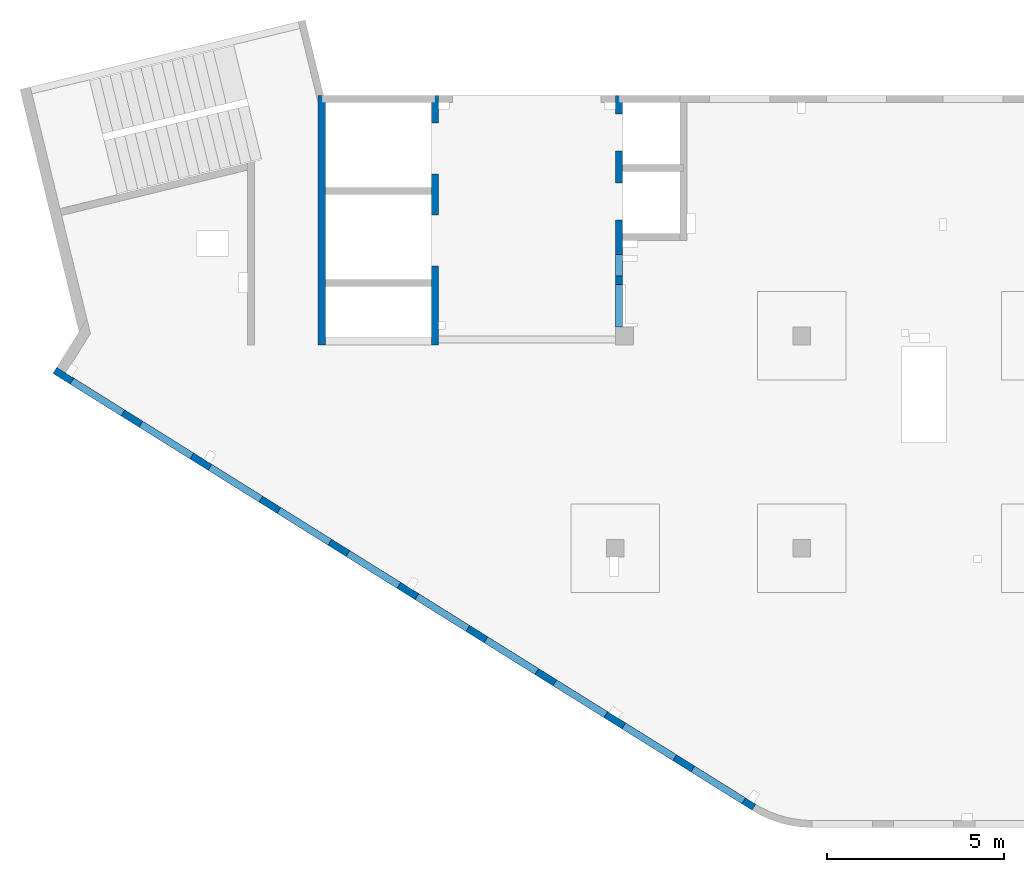
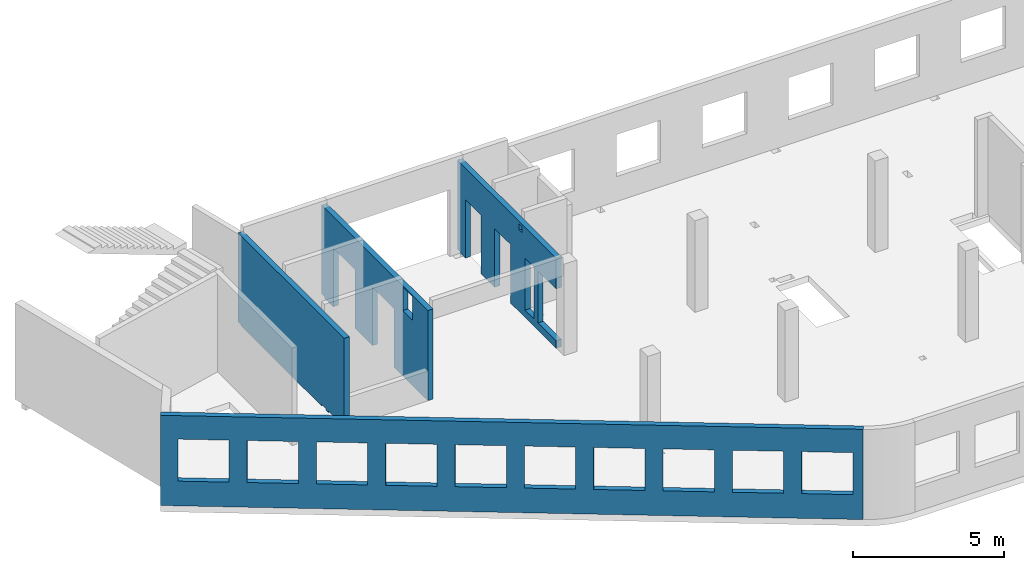
# One storey, part 4 of 6: 4 walls, 22 openings.
"""IFC4 building model written with IfcOpenShell, lengths in millimetres."""

from ifc_helpers import new_model, entity, si_unit, converted_unit, derived_unit, direction, frame, origin, place, context, subcontext, project, spatial, indexed_curve, outline, extrude, polygons, material, type_object, element, save


model = new_model("IFC4")

# Units and contexts
model_context = context("Model", 3, precision=0.01, world=origin(), true_north=direction((6.12303176911189e-17, 1.0)))
plan_context = context("Plan", 3, precision=0.01, world=origin(), true_north=direction((6.12303176911189e-17, 1.0)))
body_context = subcontext(model_context, "Body", "Model", "MODEL_VIEW")
ifc_project = project(units=[si_unit("LENGTHUNIT", "METRE", prefix="MILLI"), si_unit("AREAUNIT", "SQUARE_METRE"), si_unit("VOLUMEUNIT", "CUBIC_METRE"), converted_unit("PLANEANGLEUNIT", "DEGREE", entity("IfcRatioMeasure", 0.0174532925199433), si_unit("PLANEANGLEUNIT", "RADIAN"), dimensions=[0, 0, 0, 0, 0, 0, 0]), si_unit("MASSUNIT", "GRAM", prefix="KILO"), derived_unit("MASSDENSITYUNIT", [(si_unit("MASSUNIT", "GRAM", prefix="KILO"), 1), (si_unit("LENGTHUNIT", "METRE"), -3)]), derived_unit("MOMENTOFINERTIAUNIT", [(si_unit("LENGTHUNIT", "METRE"), 4)]), si_unit("TIMEUNIT", "SECOND"), si_unit("FREQUENCYUNIT", "HERTZ"), si_unit("THERMODYNAMICTEMPERATUREUNIT", "DEGREE_CELSIUS"), derived_unit("THERMALTRANSMITTANCEUNIT", [(si_unit("MASSUNIT", "GRAM", prefix="KILO"), 1), (si_unit("THERMODYNAMICTEMPERATUREUNIT", "KELVIN"), -1), (si_unit("TIMEUNIT", "SECOND"), -3)]), derived_unit("VOLUMETRICFLOWRATEUNIT", [(si_unit("LENGTHUNIT", "METRE"), 3), (si_unit("TIMEUNIT", "SECOND"), -1)]), derived_unit("MASSFLOWRATEUNIT", [(si_unit("MASSUNIT", "GRAM", prefix="KILO"), 1), (si_unit("TIMEUNIT", "SECOND"), -1)]), derived_unit("ROTATIONALFREQUENCYUNIT", [(si_unit("TIMEUNIT", "SECOND"), -1)]), si_unit("ELECTRICCURRENTUNIT", "AMPERE"), si_unit("ELECTRICVOLTAGEUNIT", "VOLT"), si_unit("POWERUNIT", "WATT"), si_unit("FORCEUNIT", "NEWTON", prefix="KILO"), si_unit("ILLUMINANCEUNIT", "LUX"), si_unit("LUMINOUSFLUXUNIT", "LUMEN"), si_unit("LUMINOUSINTENSITYUNIT", "CANDELA"), derived_unit("USERDEFINED", [(si_unit("MASSUNIT", "GRAM", prefix="KILO"), -1), (si_unit("LENGTHUNIT", "METRE"), -2), (si_unit("TIMEUNIT", "SECOND"), 3), (si_unit("LUMINOUSFLUXUNIT", "LUMEN"), 1)]), derived_unit("LINEARVELOCITYUNIT", [(si_unit("LENGTHUNIT", "METRE"), 1), (si_unit("TIMEUNIT", "SECOND"), -1)]), si_unit("PRESSUREUNIT", "PASCAL"), derived_unit("USERDEFINED", [(si_unit("LENGTHUNIT", "METRE"), -2), (si_unit("MASSUNIT", "GRAM", prefix="KILO"), 1), (si_unit("TIMEUNIT", "SECOND"), -2)]), derived_unit("LINEARFORCEUNIT", [(si_unit("MASSUNIT", "GRAM", prefix="KILO"), 1), (si_unit("LENGTHUNIT", "METRE"), 1), (si_unit("TIMEUNIT", "SECOND"), -2), (si_unit("LENGTHUNIT", "METRE"), -1)]), derived_unit("PLANARFORCEUNIT", [(si_unit("MASSUNIT", "GRAM", prefix="KILO"), 1), (si_unit("LENGTHUNIT", "METRE"), 1), (si_unit("TIMEUNIT", "SECOND"), -2), (si_unit("LENGTHUNIT", "METRE"), -2)])], contexts=[model_context, plan_context])

# Site, building, storey
site_placement = place(None, origin())
site = spatial("IfcSite", under=ifc_project, at=site_placement, CompositionType="ELEMENT")
building_placement = place(site_placement, origin())
building = spatial("IfcBuilding", under=site, at=building_placement, CompositionType="ELEMENT")
storey_placement = place(building_placement, frame((0.0, 0.0, 12000.0)))
storey = spatial("IfcBuildingStorey", under=building, at=storey_placement, Name="04", CompositionType="ELEMENT", Elevation=12000.0)

# Wall, openings
ifc_material = material()
wall_type = type_object("IfcWallType", Name=":ADSK_ 25_200", PredefinedType="STANDARD")
wall_1_placement = place(storey_placement, frame((19822.35, 371.16, -150.0), z_axis=(0.0, 0.0, 1.0), x_axis=(-0.848052743777574, 0.529911826412025, 0.0)))
wall_1 = element("IfcWall", 1, at=wall_1_placement, inside=storey, type_object=wall_type, material=ifc_material, Name=":ADSK_ 25_200", ObjectType=":ADSK_ 25_200", PredefinedType="NOTDEFINED", context=body_context, shape_type="Tessellation", body=[
    polygons([(-1.48894230278529e-12, -99.9999999999978, 0.0), (23011.6394501553, -99.9999999999989, 0.0), (23311.6394501553, -99.9999999999989, 0.0), (23311.6394501553, -99.9999999999989, 3650.0), (23011.6394501553, -99.9999999999989, 3650.0), (-1.48894230278529e-12, -99.9999999999978, 3650.0), (341.63903172165, -99.9999999999988, 2699.99999999999), (2041.63903172165, -99.9999999999981, 2699.99999999999), (2041.63903172165, -99.9999999999981, 1000.00000000001), (341.63903172165, -99.9999999999988, 1000.00000000001), (2641.63903172165, -99.9999999999995, 2699.99999999999), (4341.63903172165, -99.9999999999992, 2699.99999999999), (4341.63903172165, -99.9999999999992, 1000.00000000001), (2641.63903172165, -99.9999999999995, 1000.00000000001), (4941.63903172166, -100.0, 2699.99999999999), (6641.63903172166, -99.9999999999984, 2699.99999999999), (6641.63903172166, -99.9999999999984, 1000.00000000001), (4941.63903172166, -100.0, 1000.00000000001), (7241.63903172167, -99.9999999999984, 2699.99999999999), (8941.63903172167, -100.0, 2699.99999999999), (8941.63903172167, -100.0, 1000.00000000001), (7241.63903172167, -99.9999999999984, 1000.00000000001), (9541.63903172167, -100.0, 2699.99999999999), (11241.6390317217, -99.9999999999989, 2699.99999999999), (11241.6390317217, -99.9999999999989, 1000.00000000001), (9541.63903172167, -100.0, 1000.00000000001), (11841.6390317217, -100.0, 2699.99999999999), (13541.6390317217, -100.0, 2699.99999999999), (13541.6390317217, -100.0, 1000.00000000001), (11841.6390317217, -100.0, 1000.00000000001), (14141.6390317217, -100.0, 2699.99999999999), (15841.6390317217, -100.0, 2699.99999999999), (15841.6390317217, -100.0, 1000.00000000001), (14141.6390317217, -100.0, 1000.00000000001), (16441.6390317217, -99.9999999999989, 2699.99999999999), (18141.6390317217, -99.9999999999989, 2699.99999999999), (18141.6390317217, -99.9999999999989, 1000.00000000001), (16441.6390317217, -99.9999999999989, 1000.00000000001), (18741.6390317217, -100.0, 2699.99999999999), (20441.6390317217, -99.9999999999989, 2699.99999999999), (20441.6390317217, -99.9999999999989, 1000.00000000001), (18741.6390317217, -100.0, 1000.00000000001), (21041.6390317217, -99.9999999999989, 2699.99999999999), (22741.6390317217, -100.000000000001, 2699.99999999999), (22741.6390317217, -100.000000000001, 1000.00000000001), (21041.6390317217, -99.9999999999989, 1000.00000000001), (23311.6394501553, 99.9999999999989, 0.0), (-2.26725305196851e-12, 100.000000000001, 0.0), (-2.26725305196851e-12, 100.000000000001, 3650.0), (23311.6394501553, 100.000000000001, 3650.0), (2041.63903172165, 100.000000000323, 2700.0), (341.63903172165, 100.000000000321, 2700.0), (341.63903172165, 100.000000000321, 1000.00000000001), (2041.63903172165, 100.000000000323, 1000.00000000001), (4341.63903172165, 100.000000000322, 2700.0), (2641.63903172165, 100.00000000032, 2700.0), (2641.63903172165, 100.00000000032, 1000.00000000001), (4341.63903172165, 100.000000000322, 1000.00000000001), (6641.63903172166, 100.000000000322, 2700.0), (4941.63903172166, 100.000000000321, 2700.0), (4941.63903172166, 100.000000000321, 1000.00000000001), (6641.63903172166, 100.000000000322, 1000.00000000001), (8941.63903172166, 100.000000000321, 2700.0), (7241.63903172167, 100.000000000322, 2700.0), (7241.63903172167, 100.000000000322, 1000.00000000001), (8941.63903172166, 100.000000000321, 1000.00000000001), (11241.6390317217, 100.000000000323, 2700.0), (9541.63903172167, 100.000000000321, 2700.0), (9541.63903172167, 100.000000000321, 1000.00000000001), (11241.6390317217, 100.000000000323, 1000.00000000001), (13541.6390317217, 100.000000000319, 2700.0), (11841.6390317217, 100.000000000323, 2700.0), (11841.6390317217, 100.000000000323, 1000.00000000001), (13541.6390317217, 100.000000000319, 1000.00000000001), (15841.6390317217, 100.000000000322, 2700.0), (14141.6390317217, 100.000000000322, 2700.0), (14141.6390317217, 100.000000000322, 1000.00000000001), (15841.6390317217, 100.000000000322, 1000.00000000001), (18141.6390317217, 100.000000000322, 2700.0), (16441.6390317217, 100.000000000322, 2700.0), (16441.6390317217, 100.000000000322, 1000.00000000001), (18141.6390317217, 100.000000000322, 1000.00000000001), (20441.6390317217, 100.000000000322, 2700.0), (18741.6390317217, 100.000000000319, 2700.0), (18741.6390317217, 100.000000000319, 1000.00000000001), (20441.6390317217, 100.000000000322, 1000.00000000001), (22741.6390317217, 100.000000000319, 2700.0), (21041.6390317217, 100.000000000321, 2700.0), (21041.6390317217, 100.000000000323, 1000.00000000001), (22741.6390317217, 100.000000000319, 1000.00000000001)], [[[1, 2, 3, 4, 5, 6], [7, 8, 9, 10], [11, 12, 13, 14], [15, 16, 17, 18], [19, 20, 21, 22], [23, 24, 25, 26], [27, 28, 29, 30], [31, 32, 33, 34], [35, 36, 37, 38], [39, 40, 41, 42], [43, 44, 45, 46]], [[47, 48, 49, 50], [51, 52, 53, 54], [55, 56, 57, 58], [59, 60, 61, 62], [63, 64, 65, 66], [67, 68, 69, 70], [71, 72, 73, 74], [75, 76, 77, 78], [79, 80, 81, 82], [83, 84, 85, 86], [87, 88, 89, 90]], [[3, 2, 1, 48, 47]], [[6, 5, 4, 50, 49]], [[1, 6, 49, 48]], [[4, 3, 47, 50]], [[52, 51, 8, 7]], [[52, 7, 10, 53]], [[53, 10, 9, 54]], [[8, 51, 54, 9]], [[56, 55, 12, 11]], [[56, 11, 14, 57]], [[57, 14, 13, 58]], [[12, 55, 58, 13]], [[60, 59, 16, 15]], [[60, 15, 18, 61]], [[61, 18, 17, 62]], [[16, 59, 62, 17]], [[64, 63, 20, 19]], [[64, 19, 22, 65]], [[65, 22, 21, 66]], [[20, 63, 66, 21]], [[68, 67, 24, 23]], [[68, 23, 26, 69]], [[69, 26, 25, 70]], [[24, 67, 70, 25]], [[72, 71, 28, 27]], [[72, 27, 30, 73]], [[73, 30, 29, 74]], [[28, 71, 74, 29]], [[76, 75, 32, 31]], [[76, 31, 34, 77]], [[77, 34, 33, 78]], [[32, 75, 78, 33]], [[80, 79, 36, 35]], [[80, 35, 38, 81]], [[81, 38, 37, 82]], [[36, 79, 82, 37]], [[84, 83, 40, 39]], [[84, 39, 42, 85]], [[85, 42, 41, 86]], [[40, 83, 86, 41]], [[88, 87, 44, 43]], [[88, 43, 46, 89]], [[89, 46, 45, 90]], [[44, 87, 90, 45]]], closed=True),
])
placement_1 = place(wall_1_placement, frame((16613.72, 10818.86, 150.0), z_axis=(0.0, 0.0, 1.0), x_axis=(-0.848052743777574, -0.529911826412026, 0.0)))
element("IfcOpeningElement", 2, at=placement_1, cuts=wall_1, Name=":ADSK_ 25_200", PredefinedType="OPENING", context=body_context, shape_type="SweptSolid", body=[
    extrude(outline(indexed_curve([(-849.999999999993, -850.0), (849.999999999995, -850.0), (849.999999999995, 850.0), (-849.999999999993, 850.0), (-849.999999999993, -850.0)], self_intersect=False)), frame((1310.08, 12056.6, 1700.0), z_axis=(-0.529911826412026, -0.848052743777574, 0.0), x_axis=(0.0, 0.0, -1.0)), (0.0, 0.0, 1.0), 200.000000000964),
])
element("IfcOpeningElement", 3, at=placement_1, cuts=wall_1, Name=":ADSK_ 25_200", PredefinedType="OPENING", context=body_context, shape_type="SweptSolid", body=[
    extrude(outline(indexed_curve([(-849.999999999993, -850.0), (849.999999999995, -850.0), (849.999999999995, 850.0), (-849.999999999993, 850.0), (-849.999999999993, -850.0)], self_intersect=False)), frame((3260.6, 10837.81, 1700.0), z_axis=(-0.529911826412026, -0.848052743777574, 0.0), x_axis=(0.0, 0.0, -1.0)), (0.0, 0.0, 1.0), 200.000000000964),
])
element("IfcOpeningElement", 4, at=placement_1, cuts=wall_1, Name=":ADSK_ 25_200", PredefinedType="OPENING", context=body_context, shape_type="SweptSolid", body=[
    extrude(outline(indexed_curve([(-849.999999999993, -850.0), (849.999999999995, -850.0), (849.999999999995, 850.0), (-849.999999999993, 850.0), (-849.999999999993, -850.0)], self_intersect=False)), frame((5211.12, 9619.01, 1700.0), z_axis=(-0.529911826412025, -0.848052743777574, 0.0), x_axis=(0.0, 0.0, -1.0)), (0.0, 0.0, 1.0), 200.000000000962),
])
element("IfcOpeningElement", 5, at=placement_1, cuts=wall_1, Name=":ADSK_ 25_200", PredefinedType="OPENING", context=body_context, shape_type="SweptSolid", body=[
    extrude(outline(indexed_curve([(-849.999999999993, -849.999999999999), (849.999999999995, -849.999999999999), (849.999999999995, 850.0), (-849.999999999993, 850.0), (-849.999999999993, -849.999999999999)], self_intersect=False)), frame((7161.64, 8400.21, 1700.0), z_axis=(-0.529911826412026, -0.848052743777574, 0.0), x_axis=(0.0, 0.0, -1.0)), (0.0, 0.0, 1.0), 200.000000000962),
])
element("IfcOpeningElement", 6, at=placement_1, cuts=wall_1, Name=":ADSK_ 25_200", PredefinedType="OPENING", context=body_context, shape_type="SweptSolid", body=[
    extrude(outline(indexed_curve([(-849.999999999993, -849.999999999999), (849.999999999995, -849.999999999999), (849.999999999995, 850.0), (-849.999999999993, 850.0), (-849.999999999993, -849.999999999999)], self_intersect=False)), frame((9112.16, 7181.41, 1700.0), z_axis=(-0.529911826412026, -0.848052743777574, 0.0), x_axis=(0.0, 0.0, -1.0)), (0.0, 0.0, 1.0), 200.000000000962),
])
element("IfcOpeningElement", 7, at=placement_1, cuts=wall_1, Name=":ADSK_ 25_200", PredefinedType="OPENING", context=body_context, shape_type="SweptSolid", body=[
    extrude(outline(indexed_curve([(-849.999999999993, -850.0), (849.999999999995, -850.0), (849.999999999995, 850.0), (-849.999999999993, 850.0), (-849.999999999993, -850.0)], self_intersect=False)), frame((11062.68, 5962.62, 1700.0), z_axis=(-0.529911826412025, -0.848052743777574, 0.0), x_axis=(0.0, 0.0, -1.0)), (0.0, 0.0, 1.0), 200.000000000964),
])
element("IfcOpeningElement", 8, at=placement_1, cuts=wall_1, Name=":ADSK_ 25_200", PredefinedType="OPENING", context=body_context, shape_type="SweptSolid", body=[
    extrude(outline(indexed_curve([(-849.999999999993, -850.0), (849.999999999995, -850.0), (849.999999999995, 850.0), (-849.999999999993, 850.0), (-849.999999999993, -850.0)], self_intersect=False)), frame((13013.21, 4743.82, 1700.0), z_axis=(-0.529911826412025, -0.848052743777574, 0.0), x_axis=(0.0, 0.0, -1.0)), (0.0, 0.0, 1.0), 200.000000000959),
])
element("IfcOpeningElement", 9, at=placement_1, cuts=wall_1, Name=":ADSK_ 25_200", PredefinedType="OPENING", context=body_context, shape_type="SweptSolid", body=[
    extrude(outline(indexed_curve([(-849.999999999993, -850.000000000002), (849.999999999995, -850.000000000002), (849.999999999995, 849.999999999998), (-849.999999999993, 849.999999999998), (-849.999999999993, -850.000000000002)], self_intersect=False)), frame((14963.73, 3525.02, 1700.0), z_axis=(-0.529911826412025, -0.848052743777574, 0.0), x_axis=(0.0, 0.0, -1.0)), (0.0, 0.0, 1.0), 200.000000000962),
])
element("IfcOpeningElement", 10, at=placement_1, cuts=wall_1, Name=":ADSK_ 25_200", PredefinedType="OPENING", context=body_context, shape_type="SweptSolid", body=[
    extrude(outline(indexed_curve([(-849.999999999993, -850.0), (849.999999999995, -850.0), (849.999999999995, 850.0), (-849.999999999993, 850.0), (-849.999999999993, -850.0)], self_intersect=False)), frame((16914.25, 2306.23, 1700.0), z_axis=(-0.529911826412025, -0.848052743777574, 0.0), x_axis=(0.0, 0.0, -1.0)), (0.0, 0.0, 1.0), 200.000000000962),
])
element("IfcOpeningElement", 11, at=placement_1, cuts=wall_1, Name=":ADSK_ 25_200", PredefinedType="OPENING", context=body_context, shape_type="SweptSolid", body=[
    extrude(outline(indexed_curve([(-849.999999999993, -850.0), (849.999999999995, -850.0), (849.999999999995, 850.0), (-849.999999999993, 850.0), (-849.999999999993, -850.0)], self_intersect=False)), frame((18864.77, 1087.43, 1700.0), z_axis=(-0.529911826412025, -0.848052743777574, 0.0), x_axis=(0.0, 0.0, -1.0)), (0.0, 0.0, 1.0), 200.000000000966),
])

wall_2_placement = place(storey_placement, frame((16000.0, 20500.0, -150.0), z_axis=(0.0, 0.0, 1.0), x_axis=(0.0, -1.0, 0.0)))
wall_2 = element("IfcWall", 12, at=wall_2_placement, inside=storey, type_object=wall_type, material=ifc_material, Name=":ADSK_ 25_200", ObjectType=":ADSK_ 25_200", PredefinedType="NOTDEFINED", context=body_context, shape_type="Tessellation", body=[
    polygons([(4100.00063936683, -100.000000000321, 3550.0), (4300.00063936683, -100.00000000032, 3550.0), (4300.00063936683, -100.00000000032, 3300.00000000001), (4100.00063936683, -100.000000000321, 3300.00000000001), (4500.00063936683, -99.9999999999995, 2399.99999999999), (5100.00063936683, -100.000000000001, 2399.99999999999), (5100.00063936683, -100.000000000001, 300.000000000001), (4500.00063936683, -99.9999999999995, 300.000000000001), (6550.00048980714, -99.9999999999982, 3650.0), (400.000000000009, -99.9999999999998, 3650.0), (200.000000000002, -100.0, 3650.0), (0.0, -100.0, 3650.0), (0.0, -100.0, 49.9999999999973), (200.000000000002, -100.0, 49.9999999999973), (200.000000000002, -100.0, 0.0), (529.999999999996, -99.9999999999995, 0.0), (529.999999999996, -99.9999999999995, 2369.99999999804), (1570.0, -100.000000000002, 2369.99999999804), (1570.0, -100.000000000002, 0.0), (2480.0, -100.000000000001, 0.0), (2480.0, -100.000000000001, 2369.99999999804), (3519.99999999999, -100.000000000001, 2369.99999999804), (3519.99999999999, -100.000000000001, 0.0), (6550.00048980714, -99.9999999999982, 0.0), (6550.00048980714, -99.9999999999982, 300.000000000001), (5350.00048980714, -100.0, 300.000000000001), (5350.00048980714, -100.0, 2399.99999999999), (6550.00048980714, -99.9999999999982, 2399.99999999999), (4300.00063936683, 100.0, 3550.0), (4100.00063936683, 99.9999999999999, 3550.0), (4100.00063936683, 99.9999999999999, 3300.00000000001), (4300.00063936683, 100.0, 3300.00000000001), (5100.00063936683, 99.9999999999994, 2399.99999999999), (4500.00063936683, 99.9999999999984, 2399.99999999998), (4500.00063936683, 99.9999999999984, 300.000000000001), (5100.00063936683, 99.9999999999994, 300.000000000001), (0.0, 99.9999999999996, 3650.0), (200.000000000002, 99.9999999999999, 3650.0), (3900.00063936685, 99.9999999999995, 3650.0), (4100.00063936685, 99.9999999999999, 3650.0), (4300.00063936685, 100.0, 3650.0), (4525.00063936685, 100.000000000001, 3650.0), (4685.00063936685, 99.9999999999987, 3650.0), (5340.00063936685, 99.9999999999998, 3650.0), (6530.00063936685, 99.9999999999996, 3650.0), (6550.00048980714, 99.9999999999996, 3650.0), (6550.00048980714, 99.9999999999996, 2399.99999999999), (5350.00048980714, 99.9999999999998, 2399.99999999998), (5350.00048980714, 99.9999999999998, 300.000000000001), (6550.00048980714, 99.9999999999996, 300.000000000001), (6550.00048980714, 99.9999999999996, 0.0), (4100.00063936683, 99.9999999999999, 0.0), (3900.00063936683, 99.9999999999995, 0.0), (3519.99999999999, 99.9999999999989, 0.0), (3519.99999999999, 99.9999999999989, 2369.99999999804), (2480.0, 100.000000000002, 2369.99999999804), (2480.0, 100.000000000002, 0.0), (1570.0, 100.0, 0.0), (1570.0, 100.0, 2369.99999999804), (529.999999999996, 100.0, 2369.99999999804), (529.999999999996, 100.0, 0.0), (200.000000000002, 99.9999999999999, 0.0), (200.000000000002, 99.9999999999999, 49.9999999999973), (0.0, 99.9999999999996, 49.9999999999973), (200.000000000002, 9.88347789881356e-13, 0.0), (0.0, 6.56688670961758e-13, 3650.0)], [[[9, 10, 11, 12, 13, 14, 15, 16, 17, 18, 19, 20, 21, 22, 23, 24, 25, 26, 27, 28], [1, 2, 3, 4], [5, 6, 7, 8]], [[37, 38, 39, 40, 41, 42, 43, 44, 45, 46, 47, 48, 49, 50, 51, 52, 53, 54, 55, 56, 57, 58, 59, 60, 61, 62, 63, 64], [29, 30, 31, 32], [33, 34, 35, 36]], [[16, 15, 65, 62, 61]], [[24, 51, 50, 25]], [[12, 11, 10, 9, 46, 45, 44, 43, 42, 41, 40, 39, 38, 37, 66]], [[2, 1, 30, 29]], [[2, 29, 32, 3]], [[3, 32, 31, 4]], [[30, 1, 4, 31]], [[33, 6, 5, 34]], [[34, 5, 8, 35]], [[35, 8, 7, 36]], [[6, 33, 36, 7]], [[27, 48, 47, 28]], [[48, 27, 26, 49]], [[49, 26, 25, 50]], [[55, 22, 21, 56]], [[56, 21, 20, 57]], [[22, 55, 54, 23]], [[59, 18, 17, 60]], [[60, 17, 16, 61]], [[18, 59, 58, 19]], [[15, 14, 63, 62, 65]], [[13, 12, 66, 37, 64]], [[64, 63, 14, 13]], [[46, 9, 28, 47]], [[57, 20, 19, 58]], [[51, 24, 23, 54, 53, 52]]], closed=True),
])
placement_2 = place(wall_2_placement, frame((20500.0, -16000.0, 150.0), z_axis=(0.0, 0.0, 1.0), x_axis=(0.0, 1.0, 0.0)))
element("IfcOpeningElement", 13, at=placement_2, cuts=wall_2, Name=":ADSK_ 25_200", PredefinedType="OPENING", context=body_context, shape_type="SweptSolid", body=[
    extrude(outline(indexed_curve([(-1049.99999999999, -600.0), (1049.99999999999, -600.0), (1049.99999999999, 600.0), (-1049.99999999999, 600.0), (-1049.99999999999, -600.0)], self_intersect=False)), frame((15800.0, 14550.0, 1200.0), z_axis=(1.0, 0.0, 0.0), x_axis=(0.0, 0.0, -1.0)), (0.0, 0.0, 1.0), 400.000000001943),
])
element("IfcOpeningElement", 14, at=placement_2, cuts=wall_2, Name=":ADSK_ 25_200", PredefinedType="OPENING", context=body_context, shape_type="SweptSolid", body=[
    extrude(outline(indexed_curve([(-1184.99999999902, -520.000000000001), (1184.99999999902, -520.000000000001), (1184.99999999902, 519.999999999999), (-1184.99999999902, 519.999999999999), (-1184.99999999902, -520.000000000001)], self_intersect=False)), frame((15800.0, 17500.0, 1035.0), z_axis=(1.0, 0.0, 0.0), x_axis=(0.0, 0.0, -1.0)), (0.0, 0.0, 1.0), 400.000000001943),
])
element("IfcOpeningElement", 15, at=placement_2, cuts=wall_2, Name=":ADSK_ 25_200", PredefinedType="OPENING", context=body_context, shape_type="SweptSolid", body=[
    extrude(outline(indexed_curve([(-1184.99999999902, -519.999999999999), (1184.99999999902, -519.999999999999), (1184.99999999902, 520.000000000001), (-1184.99999999902, 520.000000000001), (-1184.99999999902, -519.999999999999)], self_intersect=False)), frame((15800.0, 19450.0, 1035.0), z_axis=(1.0, 0.0, 0.0), x_axis=(0.0, 0.0, -1.0)), (0.0, 0.0, 1.0), 400.000000001943),
])
element("IfcOpeningElement", 16, at=placement_2, cuts=wall_2, Name=":ADSK_ 25_200", PredefinedType="OPENING", context=body_context, shape_type="SweptSolid", body=[
    extrude(outline(indexed_curve([(-100.000000000001, -124.999999999993), (99.9999999999989, -124.999999999993), (99.9999999999989, 124.999999999993), (-100.000000000001, 124.999999999993), (-100.000000000001, -124.999999999993)], self_intersect=False)), frame((15900.0, 16300.0, 3275.0), z_axis=(1.0, 0.0, 0.0), x_axis=(0.0, -1.0, 0.0)), (0.0, 0.0, 1.0), 200.000000000962),
])
element("IfcOpeningElement", 17, at=placement_2, cuts=wall_2, Name=":ADSK_ 25_200", PredefinedType="OPENING", context=body_context, shape_type="SweptSolid", body=[
    extrude(outline(indexed_curve([(-1049.99999999999, -300.000000000001), (1049.99999999999, -300.000000000001), (1049.99999999999, 299.999999999999), (-1049.99999999999, 299.999999999999), (-1049.99999999999, -300.000000000001)], self_intersect=False)), frame((15800.0, 15700.0, 1200.0), z_axis=(1.0, 0.0, 0.0), x_axis=(0.0, 0.0, -1.0)), (0.0, 0.0, 1.0), 400.000000001943),
])

wall_3_placement = place(storey_placement, frame((7600.0, 20500.0, -150.0), z_axis=(0.0, 0.0, 1.0), x_axis=(0.0, -1.0, 0.0)))
wall_3 = element("IfcWall", 18, at=wall_3_placement, inside=storey, type_object=wall_type, material=ifc_material, Name=":ADSK_ 25_200", ObjectType=":ADSK_ 25_200", PredefinedType="NOTDEFINED", context=body_context, shape_type="Tessellation", body=[
    polygons([(7050.0006393668, -99.9999999999996, 3650.0), (226.500105821614, -99.9999999999996, 3650.0), (0.0, -100.000000000001, 3650.0), (0.0, -100.000000000001, 49.9999999999973), (200.000000000002, -100.000000000001, 49.9999999999973), (200.000000000002, -100.000000000001, 0.0), (226.50010582161, -99.9999999999996, 0.0), (5545.0, -100.000000000001, 0.0), (5545.0, -100.000000000001, 59.999999999995), (5855.0, -100.0, 59.999999999995), (5855.0, -100.0, 0.0), (5985.0, -100.0, 0.0), (5985.0, -100.0, 59.999999999995), (6294.99999999999, -99.9999999999997, 59.999999999995), (6294.99999999999, -99.9999999999997, 0.0), (7050.0006393668, -99.9999999999996, 0.0), (0.0, 100.0, 3650.0), (200.000000000002, 100.0, 3650.0), (6850.0006393668, 100.0, 3650.0), (7050.0006393668, 99.9999999999993, 3650.0), (7050.0006393668, 100.0, 1200.0), (7050.0006393668, 99.9999999999993, 0.0), (6850.0006393668, 100.0, 0.0), (6294.99999999999, 100.0, 0.0), (6294.99999999999, 100.000000000321, 59.999999999995), (5985.0, 100.000000000321, 59.999999999995), (5985.0, 100.000000000001, 0.0), (5855.0, 100.000000000001, 0.0), (5855.0, 100.000000000321, 59.999999999995), (5545.0, 100.000000000321, 59.999999999995), (5545.0, 100.0, 0.0), (200.000000000002, 100.0, 0.0), (200.000000000002, 100.0, 49.9999999999973), (0.0, 100.0, 49.9999999999973), (200.000000000002, -6.87656940234796e-13, 0.0), (0.0, 50.6443876577722, 3650.0), (0.0, 7.9044633377313e-14, 3650.0)], [[[1, 2, 3, 4, 5, 6, 7, 8, 9, 10, 11, 12, 13, 14, 15, 16]], [[17, 18, 19, 20, 21, 22, 23, 24, 25, 26, 27, 28, 29, 30, 31, 32, 33, 34]], [[6, 35, 32, 31, 8, 7]], [[3, 2, 1, 20, 19, 18, 17, 36, 37]], [[6, 5, 33, 32, 35]], [[4, 3, 37, 36, 17, 34]], [[13, 26, 25, 14]], [[26, 13, 12, 27]], [[14, 25, 24, 15]], [[9, 30, 29, 10]], [[30, 9, 8, 31]], [[10, 29, 28, 11]], [[34, 33, 5, 4]], [[1, 16, 22, 21, 20]], [[16, 15, 24, 23, 22]], [[27, 12, 11, 28]]], closed=True),
])
placement_3 = place(wall_3_placement, origin())
element("IfcOpeningElement", 19, at=placement_3, cuts=wall_3, Name=":ADSK_ 25_200", PredefinedType="OPENING", context=body_context, shape_type="SweptSolid", body=[
    extrude(outline(indexed_curve([(-154.999999999993, -154.999999999999), (154.999999999993, -154.999999999999), (154.999999999993, 154.999999999999), (-154.999999999993, 154.999999999999), (-154.999999999993, -154.999999999999)], self_intersect=False)), frame((6140.0, -100.0, -95.0), z_axis=(0.0, 1.0, 0.0), x_axis=(0.0, 0.0, -1.0)), (0.0, 0.0, 1.0), 200.000000000962),
])
element("IfcOpeningElement", 20, at=placement_3, cuts=wall_3, Name=":ADSK_ 25_200", PredefinedType="OPENING", context=body_context, shape_type="SweptSolid", body=[
    extrude(outline(indexed_curve([(-154.999999999993, -154.999999999999), (154.999999999993, -154.999999999999), (154.999999999993, 154.999999999999), (-154.999999999993, 154.999999999999), (-154.999999999993, -154.999999999999)], self_intersect=False)), frame((5700.0, -100.0, -95.0), z_axis=(0.0, 1.0, 0.0), x_axis=(0.0, 0.0, -1.0)), (0.0, 0.0, 1.0), 200.000000000962),
])
placement_4 = place(wall_3_placement, frame((20500.0, -7600.0, 150.0), z_axis=(0.0, 0.0, 1.0), x_axis=(0.0, 1.0, 0.0)))
element("IfcOpeningElement", 21, at=placement_4, cuts=wall_3, Name=":ADSK_ 25_200", PredefinedType="OPENING", context=body_context, shape_type="SweptSolid", body=[
    extrude(outline(indexed_curve([(-154.999999999995, -154.999999999999), (154.999999999991, -154.999999999999), (154.999999999991, 154.999999999999), (-154.999999999995, 154.999999999999), (-154.999999999995, -154.999999999999)], self_intersect=False)), frame((7500.0, 14360.0, 3655.0), z_axis=(1.0, 0.0, 0.0), x_axis=(0.0, 0.0, -1.0)), (0.0, 0.0, 1.0), 200.000000000962),
])
element("IfcOpeningElement", 22, at=placement_4, cuts=wall_3, Name=":ADSK_ 25_200", PredefinedType="OPENING", context=body_context, shape_type="SweptSolid", body=[
    extrude(outline(indexed_curve([(-154.999999999995, -154.999999999999), (154.999999999991, -154.999999999999), (154.999999999991, 154.999999999999), (-154.999999999995, 154.999999999999), (-154.999999999995, -154.999999999999)], self_intersect=False)), frame((7500.0, 14800.0, 3655.0), z_axis=(1.0, 0.0, 0.0), x_axis=(0.0, 0.0, -1.0)), (0.0, 0.0, 1.0), 200.000000000962),
])

wall_4_placement = place(storey_placement, frame((10800.0, 20500.0, -150.0), z_axis=(0.0, 0.0, 1.0), x_axis=(0.0, -1.0, 0.0)))
wall_4 = element("IfcWall", 23, at=wall_4_placement, inside=storey, type_object=wall_type, material=ifc_material, Name=":ADSK_ 25_200", ObjectType=":ADSK_ 25_200", PredefinedType="NOTDEFINED", context=body_context, shape_type="Tessellation", body=[
    polygons([(5400.00000000002, -99.999999999999, 3600.0), (6050.00000000002, -99.9999999999979, 3600.0), (6050.00000000002, -99.9999999999979, 2650.00000000001), (5400.00000000002, -99.999999999999, 2650.00000000001), (7050.00063936683, -99.9999999999985, 3650.0), (6850.00063936682, -99.9999999999988, 3650.0), (200.000000000028, -99.9999999999985, 3650.0), (0.0, -99.9999999999988, 3650.0), (0.0, -99.9999999999988, 49.9999999999973), (200.000000000028, -99.9999999999985, 49.9999999999973), (200.000000000028, -99.9999999999985, 0.0), (780.000000000018, -99.9999999999976, 0.0), (780.000000000018, -99.9999999999976, 2369.99999999804), (2220.00000000001, -99.9999999999975, 2369.99999999804), (2220.00000000001, -99.9999999999975, 0.0), (3380.00000000002, -99.9999999999978, 0.0), (3380.00000000002, -99.9999999999978, 2369.99999999804), (4820.00000000001, -99.9999999999977, 2369.99999999804), (4820.00000000001, -99.9999999999977, 0.0), (6850.00063936683, -99.9999999999988, 0.0), (7050.00063936683, -99.9999999999985, 0.0), (7050.00063936683, -99.9999999999985, 1200.0), (0.0, 100.000000000001, 3650.0), (200.000000000002, 100.000000000001, 3650.0), (400.00000000003, 100.000000000002, 3650.0), (6400.00063936682, 100.0, 3650.0), (6600.00063936682, 100.000000000001, 3650.0), (7050.00063936683, 100.000000000001, 3650.0), (7050.00063936683, 100.000000000001, 0.0), (6600.00063936682, 100.000000000001, 0.0), (6400.00063936682, 100.0, 0.0), (4820.00000000001, 100.000000000002, 0.0), (4820.00000000002, 100.000000000002, 2369.99999999804), (3380.00000000002, 100.000000000002, 2369.99999999804), (3380.00000000002, 100.000000000002, 0.0), (2220.00000000001, 100.000000000003, 0.0), (2220.00000000001, 100.000000000003, 2369.99999999804), (780.000000000018, 100.000000000002, 2369.99999999804), (780.000000000018, 100.000000000002, 0.0), (400.00000000003, 100.000000000002, 0.0), (200.000000000028, 100.000000000001, 0.0), (200.000000000028, 100.000000000001, 49.9999999999973), (0.0, 100.000000000001, 49.9999999999973), (6050.00000000002, 100.000000000323, 3600.0), (5400.00000000002, 100.000000000322, 3600.0), (5400.00000000002, 100.000000000322, 2650.00000000001), (6050.00000000002, 100.000000000323, 2650.00000000001), (0.0, 7.90446333772861e-14, 3650.0), (200.000000000028, 3.95210189063612e-13, 49.9999999999973), (0.0, 7.90446333772861e-14, 49.9999999999973)], [[[5, 6, 7, 8, 9, 10, 11, 12, 13, 14, 15, 16, 17, 18, 19, 20, 21, 22], [1, 2, 3, 4]], [[23, 24, 25, 26, 27, 28, 29, 30, 31, 32, 33, 34, 35, 36, 37, 38, 39, 40, 41, 42, 43], [44, 45, 46, 47]], [[12, 11, 41, 40, 39]], [[8, 7, 6, 5, 28, 27, 26, 25, 24, 23, 48]], [[45, 44, 2, 1]], [[45, 1, 4, 46]], [[46, 4, 3, 47]], [[2, 44, 47, 3]], [[13, 38, 37, 14]], [[14, 37, 36, 15]], [[38, 13, 12, 39]], [[33, 18, 17, 34]], [[34, 17, 16, 35]], [[18, 33, 32, 19]], [[43, 42, 49, 10, 9, 50]], [[11, 10, 49, 42, 41]], [[9, 8, 48, 23, 43, 50]], [[5, 22, 21, 29, 28]], [[15, 36, 35, 16]], [[29, 21, 20, 19, 32, 31, 30]]], closed=True),
])
placement_5 = place(wall_4_placement, frame((20500.0, -10800.0, 150.0), z_axis=(0.0, 0.0, 1.0), x_axis=(0.0, 1.0, 0.0)))
element("IfcOpeningElement", 24, at=placement_5, cuts=wall_4, Name=":ADSK_ 25_200", PredefinedType="OPENING", context=body_context, shape_type="SweptSolid", body=[
    extrude(outline(indexed_curve([(-719.999999999999, -1184.99999999902), (719.999999999999, -1184.99999999902), (719.999999999999, 1184.99999999902), (-719.999999999999, 1184.99999999902), (-719.999999999999, -1184.99999999902)], self_intersect=False)), frame((10600.0, 19000.0, 1035.0), z_axis=(1.0, 0.0, 0.0), x_axis=(0.0, -1.0, 0.0)), (0.0, 0.0, 1.0), 400.000000001943),
])
element("IfcOpeningElement", 25, at=placement_5, cuts=wall_4, Name=":ADSK_ 25_200", PredefinedType="OPENING", context=body_context, shape_type="SweptSolid", body=[
    extrude(outline(indexed_curve([(-1184.99999999902, -719.999999999999), (1184.99999999902, -719.999999999999), (1184.99999999902, 720.000000000001), (-1184.99999999902, 720.000000000001), (-1184.99999999902, -719.999999999999)], self_intersect=False)), frame((10600.0, 16400.0, 1035.0), z_axis=(1.0, 0.0, 0.0), x_axis=(0.0, 0.0, -1.0)), (0.0, 0.0, 1.0), 400.000000001943),
])
element("IfcOpeningElement", 26, at=placement_5, cuts=wall_4, Name=":ADSK_ 25_200", PredefinedType="OPENING", context=body_context, shape_type="SweptSolid", body=[
    extrude(outline(indexed_curve([(-474.999999999994, -325.0), (474.999999999992, -325.0), (474.999999999992, 325.0), (-474.999999999994, 325.0), (-474.999999999994, -325.0)], self_intersect=False)), frame((10700.0, 14775.0, 2975.0), z_axis=(1.0, 0.0, 0.0), x_axis=(0.0, 0.0, -1.0)), (0.0, 0.0, 1.0), 200.000000000962),
])

save(model, "model.ifc")
